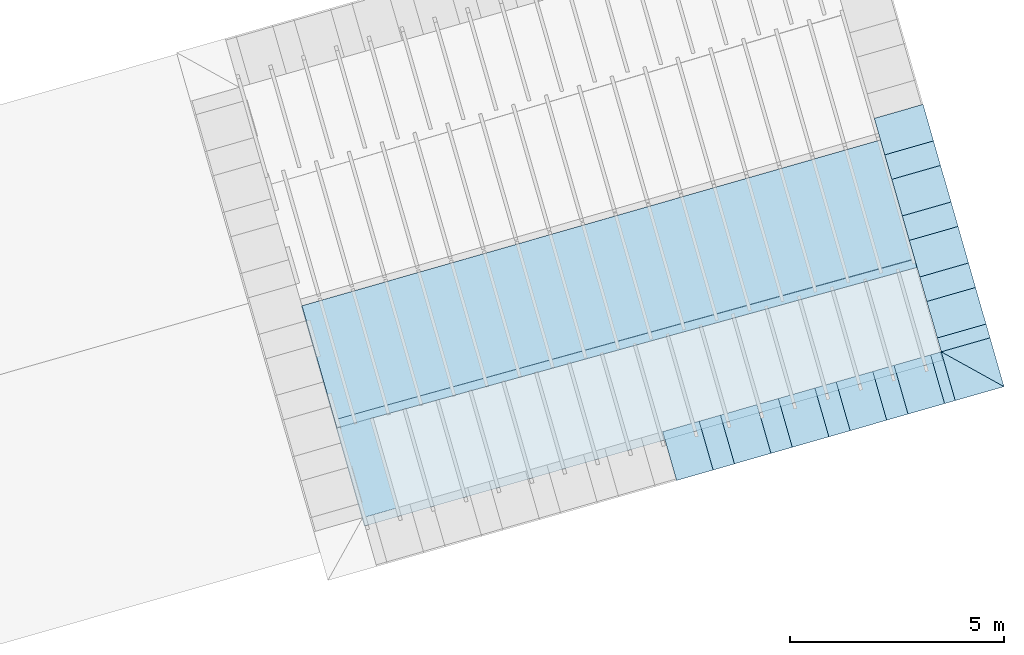
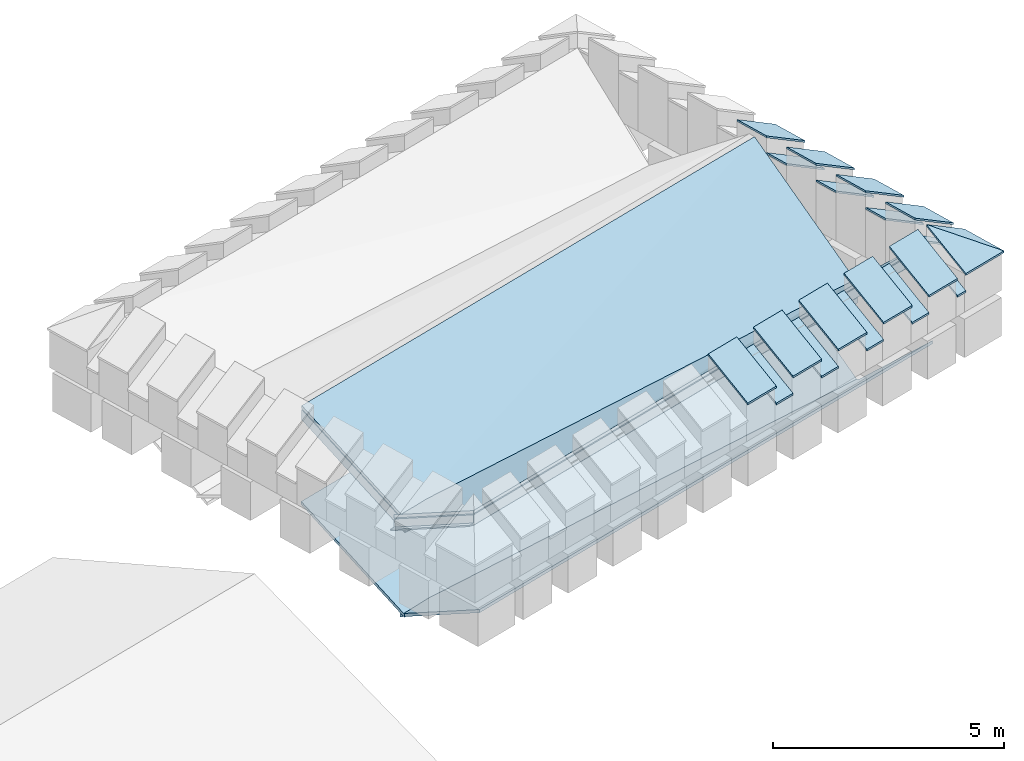
# One storey, part 3 of 10: 26 roofs.
"""IFC4 building model written with IfcOpenShell, lengths in metres."""

from ifc_helpers import new_model, entity, si_unit, converted_unit, derived_unit, direction, frame, origin_with_axes, place, context, subcontext, project, spatial, polygons, material, type_object, element, save


model = new_model("IFC4")

# Units and contexts
model_context = context("Model", 3, precision=1e-05, world=origin_with_axes(), true_north=direction((0.0, 1.0)))
body_context = subcontext(model_context, "Body", "Model", "MODEL_VIEW")
ifc_project = project(units=[si_unit("LENGTHUNIT", "METRE"), si_unit("AREAUNIT", "SQUARE_METRE"), si_unit("VOLUMEUNIT", "CUBIC_METRE"), converted_unit("PLANEANGLEUNIT", "DEGREE", entity("IfcPlaneAngleMeasure", 0.0174532925199433), si_unit("PLANEANGLEUNIT", "RADIAN"), dimensions=[0, 0, 0, 0, 0, 0, 0]), converted_unit("TIMEUNIT", "Year", entity("IfcTimeMeasure", 31557600.0), si_unit("TIMEUNIT", "SECOND"), dimensions=[0, 0, 1, 0, 0, 0, 0]), si_unit("MASSUNIT", "GRAM", prefix="KILO"), si_unit("THERMODYNAMICTEMPERATUREUNIT", "DEGREE_CELSIUS"), si_unit("LUMINOUSINTENSITYUNIT", "LUMEN"), si_unit("ENERGYUNIT", "JOULE", prefix="MEGA"), derived_unit("THERMALCONDUCTANCEUNIT", [(si_unit("POWERUNIT", "WATT"), 1), (si_unit("LENGTHUNIT", "METRE"), -1), (si_unit("THERMODYNAMICTEMPERATUREUNIT", "KELVIN"), -1)]), derived_unit("SPECIFICHEATCAPACITYUNIT", [(si_unit("ENERGYUNIT", "JOULE"), 1), (si_unit("MASSUNIT", "GRAM", prefix="KILO"), -1), (si_unit("THERMODYNAMICTEMPERATUREUNIT", "KELVIN"), -1)]), derived_unit("MASSDENSITYUNIT", [(si_unit("MASSUNIT", "GRAM", prefix="KILO"), 1), (si_unit("VOLUMEUNIT", "CUBIC_METRE"), -1)])], contexts=[model_context])

# Site, building, storey
site_placement = place(None, frame((0.0, 0.0, 0.0), z_axis=(0.0, 0.0, 1.0), x_axis=(0.9612616959383189, 0.2756373558169991, 0.0)))
site = spatial("IfcSite", under=ifc_project, at=site_placement, CompositionType="ELEMENT")
building_placement = place(site_placement, origin_with_axes())
building = spatial("IfcBuilding", under=site, at=building_placement, CompositionType="ELEMENT")
storey_placement = place(building_placement, frame((0.0, 0.0, 11.0), z_axis=(0.0, 0.0, 1.0), x_axis=(1.0, 0.0, 0.0)))
storey = spatial("IfcBuildingStorey", under=building, at=storey_placement, Name="Dach", CompositionType="ELEMENT", Elevation=11.0)

# Roofs
ifc_material_1 = material(Name="schwarz")
roof_type_1 = type_object("IfcRoofType", Name="schwarz 43", PredefinedType="NOTDEFINED")
roof_1_placement = place(storey_placement, frame((31.60143138517464, 8.011806750439922, 1.213699999999999), z_axis=(0.0, 0.0, 1.0), x_axis=(0.0, 1.0, 0.0)))
element("IfcRoof", 1, at=roof_1_placement, inside=storey, type_object=roof_type_1, material=ifc_material_1, Name="Dach-060", PredefinedType="NOTDEFINED", context=body_context, shape_type="Tessellation", body=[
    polygons([(0.8900025616952458, -0.03772698703640387, 0.02714466037988217), (0.8900025616952494, 1.149999999999988, 0.7466800857374203), (0.0, 1.149999999999991, 0.7466800857374274), (0.0, -0.03772698703641097, 0.02714466037987862), (0.8900025620847654, -0.03772698691103571, -0.02285533967409847), (0.8900025620847671, 1.150000000333105, 0.6966800858092981), (3.51640494500316e-10, 1.150000000333105, 0.6966800858092981), (3.516387181434766e-10, -0.03772698691103571, -0.02285533967409847)], [[[1, 2, 3, 4]], [[2, 1, 5, 6]], [[3, 2, 6, 7]], [[4, 3, 7, 8]], [[1, 4, 8, 5]], [[6, 5, 8, 7]]], closed=True),
])
roof_2_placement = place(storey_placement, frame((31.6014313850233, 9.498212015342238, 1.213699999999999), z_axis=(0.0, 0.0, 1.0), x_axis=(0.0, 1.0, 0.0)))
element("IfcRoof", 2, at=roof_2_placement, inside=storey, type_object=roof_type_1, material=ifc_material_1, Name="Dach-060", PredefinedType="NOTDEFINED", context=body_context, shape_type="Tessellation", body=[
    polygons([(0.8900025616952458, -0.03772698703641097, 0.02714466037987862), (0.8900025616952494, 1.149999999999984, 0.7466800857374238), (0.0, 1.149999999999999, 0.7466800857374309), (0.0, -0.03772698703641097, 0.02714466037987862), (0.8900025620847654, -0.03772698691103216, -0.02285533967409137), (0.8900025620847671, 1.150000000333108, 0.6966800858093052), (3.51640494500316e-10, 1.150000000333108, 0.6966800858093052), (3.516387181434766e-10, -0.03772698691103216, -0.02285533967409137)], [[[1, 2, 3, 4]], [[2, 1, 5, 6]], [[3, 2, 6, 7]], [[4, 3, 7, 8]], [[1, 4, 8, 5]], [[6, 5, 8, 7]]], closed=True),
])
roof_3_placement = place(storey_placement, frame((31.60143138487195, 10.98461728024455, 1.213699999999999), z_axis=(0.0, 0.0, 1.0), x_axis=(0.0, 1.0, 0.0)))
element("IfcRoof", 3, at=roof_3_placement, inside=storey, type_object=roof_type_1, material=ifc_material_1, Name="Dach-060", PredefinedType="NOTDEFINED", context=body_context, shape_type="Tessellation", body=[
    polygons([(0.8900025616952458, -0.03772698703640387, 0.02714466037988217), (0.8900025616952494, 1.149999999999988, 0.7466800857374203), (0.0, 1.150000000000002, 0.7466800857374274), (0.0, -0.03772698703641097, 0.02714466037987862), (0.8900025620847654, -0.0377269869110286, -0.02285533967409492), (0.8900025620847671, 1.150000000333112, 0.6966800858093016), (3.51640494500316e-10, 1.150000000333112, 0.6966800858093016), (3.516387181434766e-10, -0.0377269869110286, -0.02285533967409492)], [[[1, 2, 3, 4]], [[2, 1, 5, 6]], [[3, 2, 6, 7]], [[4, 3, 7, 8]], [[1, 4, 8, 5]], [[6, 5, 8, 7]]], closed=True),
])
roof_4_placement = place(storey_placement, frame((31.60143138472061, 12.47102254514687, 1.213699999999999), z_axis=(0.0, 0.0, 1.0), x_axis=(0.0, 1.0, 0.0)))
element("IfcRoof", 4, at=roof_4_placement, inside=storey, type_object=roof_type_1, material=ifc_material_1, Name="Dach-060", PredefinedType="NOTDEFINED", context=body_context, shape_type="Tessellation", body=[
    polygons([(0.8900025616952458, -0.03772698703641097, 0.02714466037987862), (0.8900025616952494, 1.149999999999988, 0.7466800857374238), (0.0, 1.149999999999999, 0.7466800857374309), (0.0, -0.03772698703641097, 0.02714466037987862), (0.8900025620847654, -0.0377269869110286, -0.02285533967409137), (0.8900025620847671, 1.150000000333112, 0.6966800858093052), (3.51640494500316e-10, 1.150000000333112, 0.6966800858093052), (3.516387181434766e-10, -0.0377269869110286, -0.02285533967409137)], [[[1, 2, 3, 4]], [[2, 1, 5, 6]], [[3, 2, 6, 7]], [[4, 3, 7, 8]], [[1, 4, 8, 5]], [[6, 5, 8, 7]]], closed=True),
])
roof_5_placement = place(storey_placement, frame((31.60143138517461, 9.498209312135137, 0.7745999999999995), z_axis=(0.0, 0.0, 1.0), x_axis=(0.0, -1.0, 0.0)))
element("IfcRoof", 5, at=roof_5_placement, inside=storey, type_object=roof_type_1, material=ifc_material_1, Name="Dach-059", PredefinedType="NOTDEFINED", context=body_context, shape_type="Tessellation", body=[
    polygons([(0.0, -1.149999999999999, 0.7466800857374309), (0.5964000000000027, -1.149999999999991, 0.7466800857374274), (0.5963999999999992, 0.03772698703645361, 0.02714466037985375), (0.0, 0.03772698703645361, 0.02714466037985375), (-3.895159750300081e-10, -1.150000000333108, 0.6966800858093052), (0.5963999997654561, -1.150000000333108, 0.6966800858093052), (0.5963999997654561, 0.03772698691103216, -0.02285533967409137), (-3.895159750300081e-10, 0.03772698691103216, -0.02285533967409137)], [[[1, 2, 3, 4]], [[2, 1, 5, 6]], [[3, 2, 6, 7]], [[4, 3, 7, 8]], [[1, 4, 8, 5]], [[6, 5, 8, 7]]], closed=True),
])
roof_6_placement = place(storey_placement, frame((31.60143138499301, 10.98461511767887, 0.7745999999999995), z_axis=(0.0, 0.0, 1.0), x_axis=(0.0, -1.0, 0.0)))
element("IfcRoof", 6, at=roof_6_placement, inside=storey, type_object=roof_type_1, material=ifc_material_1, Name="Dach-059", PredefinedType="NOTDEFINED", context=body_context, shape_type="Tessellation", body=[
    polygons([(0.0, -1.150000000000009, 0.746680085737438), (0.5964000000000027, -1.149999999999999, 0.7466800857374309), (0.5963999999999992, 0.03772698703645005, 0.0271446603798573), (0.0, 0.03772698703645005, 0.0271446603798573), (-3.895159750300081e-10, -1.150000000333122, 0.6966800858093123), (0.5963999997654561, -1.150000000333122, 0.6966800858093123), (0.5963999997654561, 0.0377269869110215, -0.02285533967408782), (-3.895159750300081e-10, 0.0377269869110215, -0.02285533967408782)], [[[1, 2, 3, 4]], [[2, 1, 5, 6]], [[3, 2, 6, 7]], [[4, 3, 7, 8]], [[1, 4, 8, 5]], [[6, 5, 8, 7]]], closed=True),
])
roof_7_placement = place(storey_placement, frame((31.6014313848114, 12.47102092322261, 0.7745999999999995), z_axis=(0.0, 0.0, 1.0), x_axis=(0.0, -1.0, 0.0)))
element("IfcRoof", 7, at=roof_7_placement, inside=storey, type_object=roof_type_1, material=ifc_material_1, Name="Dach-059", PredefinedType="NOTDEFINED", context=body_context, shape_type="Tessellation", body=[
    polygons([(0.0, -1.149999999999999, 0.7466800857374274), (0.5964000000000027, -1.149999999999995, 0.7466800857374238), (0.5963999999999992, 0.03772698703645361, 0.02714466037985019), (0.0, 0.03772698703645361, 0.02714466037985019), (-3.895159750300081e-10, -1.150000000333112, 0.6966800858093016), (0.5963999997654561, -1.150000000333112, 0.6966800858093016), (0.5963999997654561, 0.0377269869110286, -0.02285533967409492), (-3.895159750300081e-10, 0.0377269869110286, -0.02285533967409492)], [[[1, 2, 3, 4]], [[2, 1, 5, 6]], [[3, 2, 6, 7]], [[4, 3, 7, 8]], [[1, 4, 8, 5]], [[6, 5, 8, 7]]], closed=True),
])
roof_8_placement = place(storey_placement, frame((31.60143138169894, 8.011806975140747, 0.7745999999999995), z_axis=(0.0, 0.0, 1.0), x_axis=(0.0, -1.0, 0.0)))
element("IfcRoof", 8, at=roof_8_placement, inside=storey, type_object=roof_type_1, material=ifc_material_1, Name="Dach-058", PredefinedType="NOTDEFINED", context=body_context, shape_type="Tessellation", body=[
    polygons([(-7.37155403385259e-09, 0.03772698688034382, 0.0271446603290677), (2.247008605849032e-07, -1.149999996524294, 0.7466800945752929), (0.3364054846060407, -1.149999993345972, 0.7466800926498394), (0.3364054841255495, 0.03772698688034382, 0.0271446603290677), (-1.210476341384492e-08, 0.03772698706561783, -0.02285534011997115), (2.207258802400247e-07, -1.149999996857446, 0.6966800944403211), (0.3364054846092674, -1.14999999367123, 0.696680092510082), (0.3364054836779449, 0.03772698706561783, -0.02285534011997115)], [[[1, 2, 3, 4]], [[2, 1, 5, 6]], [[3, 2, 6, 7]], [[4, 3, 7, 8]], [[1, 4, 8, 5]], [[6, 5, 8, 7]]], closed=True),
])
roof_9_placement = place(storey_placement, frame((23.66662464075685, 6.525401474882883, 1.213699999999999), z_axis=(0.0, 0.0, 1.0), x_axis=(1.0, 0.0, 0.0)))
element("IfcRoof", 9, at=roof_9_placement, inside=storey, type_object=roof_type_1, material=ifc_material_1, Name="Dach-057", PredefinedType="NOTDEFINED", context=body_context, shape_type="Tessellation", body=[
    polygons([(0.8900025616952547, -0.03772698703644206, 0.0271446603798573), (0.8900025616952547, 1.15, 0.7466800857374345), (0.0, 1.15, 0.7466800857374345), (0.0, -0.03772698703644206, 0.0271446603798573), (0.8900025620847707, -0.03772698691103216, -0.0228553396740967), (0.8900025620847707, 1.150000000333107, 0.6966800858093052), (3.516440472139948e-10, 1.150000000333107, 0.6966800858093052), (3.516440472139948e-10, -0.03772698691103216, -0.0228553396740967)], [[[1, 2, 3, 4]], [[2, 1, 5, 6]], [[3, 2, 6, 7]], [[4, 3, 7, 8]], [[1, 4, 8, 5]], [[6, 5, 8, 7]]], closed=True),
])
roof_10_placement = place(storey_placement, frame((25.07558547708947, 6.525401478013255, 1.213699999999999), z_axis=(0.0, 0.0, 1.0), x_axis=(1.0, 0.0, 0.0)))
element("IfcRoof", 10, at=roof_10_placement, inside=storey, type_object=roof_type_1, material=ifc_material_1, Name="Dach-057", PredefinedType="NOTDEFINED", context=body_context, shape_type="Tessellation", body=[
    polygons([(0.8900025616952547, -0.03772698703644295, 0.0271446603798573), (0.8900025616952547, 1.15, 0.7466800857374345), (0.0, 1.149999999999999, 0.7466800857374345), (0.0, -0.03772698703644295, 0.0271446603798573), (0.8900025620847707, -0.03772698691103127, -0.0228553396740967), (0.8900025620847707, 1.150000000333108, 0.6966800858093052), (3.516440472139948e-10, 1.150000000333108, 0.6966800858093052), (3.516440472139948e-10, -0.03772698691103127, -0.0228553396740967)], [[[1, 2, 3, 4]], [[2, 1, 5, 6]], [[3, 2, 6, 7]], [[4, 3, 7, 8]], [[1, 4, 8, 5]], [[6, 5, 8, 7]]], closed=True),
])
roof_11_placement = place(storey_placement, frame((26.48454631342209, 6.525401481143627, 1.213699999999999), z_axis=(0.0, 0.0, 1.0), x_axis=(1.0, 0.0, 0.0)))
element("IfcRoof", 11, at=roof_11_placement, inside=storey, type_object=roof_type_1, material=ifc_material_1, Name="Dach-057", PredefinedType="NOTDEFINED", context=body_context, shape_type="Tessellation", body=[
    polygons([(0.8900025616952547, -0.03772698703644384, 0.02714466037985552), (0.8900025616952547, 1.149999999999999, 0.7466800857374327), (0.0, 1.149999999999999, 0.7466800857374327), (0.0, -0.03772698703644561, 0.02714466037985552), (0.8900025620847707, -0.03772698691103216, -0.02285533967409847), (0.8900025620847707, 1.150000000333106, 0.6966800858093034), (3.516440472139948e-10, 1.150000000333106, 0.6966800858093034), (3.516440472139948e-10, -0.03772698691103216, -0.02285533967409847)], [[[1, 2, 3, 4]], [[2, 1, 5, 6]], [[3, 2, 6, 7]], [[4, 3, 7, 8]], [[1, 4, 8, 5]], [[6, 5, 8, 7]]], closed=True),
])
roof_12_placement = place(storey_placement, frame((27.89346542439209, 6.525401487404372, 1.213659364809255), z_axis=(0.0, 0.0, 1.0), x_axis=(1.0, 0.0, 0.0)))
element("IfcRoof", 12, at=roof_12_placement, inside=storey, type_object=roof_type_1, material=ifc_material_1, Name="Dach-057", PredefinedType="NOTDEFINED", context=body_context, shape_type="Tessellation", body=[
    polygons([(0.8900025616952547, -0.03772698703644295, 0.02714466037985908), (0.8900025616952547, 1.149999999999999, 0.7466800857374345), (0.0, 1.149999999999999, 0.7466800857374345), (0.0, -0.03772698703644295, 0.02714466037985908), (0.8900025620847707, -0.03772698691103216, -0.0228553396740967), (0.8900025620847707, 1.150000000333107, 0.6966800858093052), (3.516440472139948e-10, 1.150000000333107, 0.6966800858093052), (3.516440472139948e-10, -0.03772698691103216, -0.0228553396740967)], [[[1, 2, 3, 4]], [[2, 1, 5, 6]], [[3, 2, 6, 7]], [[4, 3, 7, 8]], [[1, 4, 8, 5]], [[6, 5, 8, 7]]], closed=True),
])
roof_13_placement = place(storey_placement, frame((29.30246798608734, 6.525401487404372, 1.213699999999999), z_axis=(0.0, 0.0, 1.0), x_axis=(1.0, 0.0, 0.0)))
element("IfcRoof", 13, at=roof_13_placement, inside=storey, type_object=roof_type_1, material=ifc_material_1, Name="Dach-057", PredefinedType="NOTDEFINED", context=body_context, shape_type="Tessellation", body=[
    polygons([(0.8900025616952547, -0.03772698703644295, 0.0271446603798573), (0.8900025616952547, 1.149999999999999, 0.7466800857374345), (0.0, 1.149999999999999, 0.7466800857374345), (0.0, -0.03772698703644295, 0.0271446603798573), (0.8900025620847707, -0.03772698691103304, -0.0228553396740967), (0.8900025620847707, 1.150000000333106, 0.6966800858093052), (3.516440472139948e-10, 1.150000000333106, 0.6966800858093052), (3.516440472139948e-10, -0.03772698691103304, -0.0228553396740967)], [[[1, 2, 3, 4]], [[2, 1, 5, 6]], [[3, 2, 6, 7]], [[4, 3, 7, 8]], [[1, 4, 8, 5]], [[6, 5, 8, 7]]], closed=True),
])
roof_14_placement = place(storey_placement, frame((31.60143138835297, 6.525401490534742, 1.213699411030737), z_axis=(0.0, 0.0, 1.0), x_axis=(0.0, 1.0, 0.0)))
element("IfcRoof", 14, at=roof_14_placement, inside=storey, type_object=roof_type_1, material=ifc_material_1, Name="Dach-050", PredefinedType="NOTDEFINED", context=body_context, shape_type="Tessellation", body=[
    polygons([(1.149999999777758, -0.03772756924569265, 0.02714484985550847), (1.149999996544735, 1.149999999675053, 0.7466392677225802), (-0.03772756914296949, -0.03772756924566778, 0.02714484985552268), (1.15000000023677, -0.03772756894329277, -0.02285437849470462), (1.14999999651148, 1.150000000079416, 0.6966400394341346), (-0.03772756943687394, -0.03772756894329277, -0.02285437849470462)], [[[1, 2, 3]], [[2, 1, 4, 5]], [[3, 2, 5, 6]], [[1, 3, 6, 4]], [[5, 4, 6]]], closed=True),
])
roof_15_placement = place(storey_placement, frame((30.45143138835297, 6.525401490534707, 1.213699411030737), z_axis=(0.0, 0.0, 1.0), x_axis=(1.0, 0.0, 0.0)))
element("IfcRoof", 15, at=roof_15_placement, inside=storey, type_object=roof_type_1, material=ifc_material_1, Name="Dach-049", PredefinedType="NOTDEFINED", context=body_context, shape_type="Tessellation", body=[
    polygons([(1.187727569245677, -0.03772756914296682, 0.02714484989206234), (0.0, 1.149999996869653, 0.7466392679559526), (0.0, -0.0377275691429686, 0.02714484989206234), (1.187727569633864, -0.03772756928762089, -0.02285437876549956), (0.0, 1.149999997201504, 0.6966400395870433), (0.0, -0.03772756928762089, -0.02285437876549956)], [[[1, 2, 3]], [[2, 1, 4, 5]], [[3, 2, 5, 6]], [[1, 3, 6, 4]], [[5, 4, 6]]], closed=True),
])
roof_16_placement = place(storey_placement, frame((27.37454887510356, 6.543388480039594, 0.774556042697311), z_axis=(0.0, 0.0, 1.0), x_axis=(1.0, 0.0, 0.0)))
element("IfcRoof", 16, at=roof_16_placement, inside=storey, type_object=roof_type_1, material=ifc_material_1, Name="Dach-048", PredefinedType="NOTDEFINED", context=body_context, shape_type="Tessellation", body=[
    polygons([(0.5189582746531372, -0.05571398314985654, 0.01624798038468356), (0.51895827465313, 1.132013003886586, 0.7357834057422608), (0.0, 1.132013003886584, 0.735783405742259), (0.0, -0.0557139831498592, 0.01624798038468178), (0.5189582750426531, -0.05571398302444663, -0.03375201966927044), (0.5189582750426531, 1.132013004219693, 0.6857834058141314), (-1.637339153148787e-10, 1.132013004219693, 0.6857834058141314), (-1.637339153148787e-10, -0.05571398302444663, -0.03375201966927044)], [[[1, 2, 3, 4]], [[2, 1, 5, 6]], [[3, 2, 6, 7]], [[4, 3, 7, 8]], [[1, 4, 8, 5]], [[6, 5, 8, 7]]], closed=True),
])
roof_17_placement = place(storey_placement, frame((28.78350971143421, 6.543388483517785, 0.7745999999999995), z_axis=(0.0, 0.0, 1.0), x_axis=(1.0, 0.0, 0.0)))
element("IfcRoof", 17, at=roof_17_placement, inside=storey, type_object=roof_type_1, material=ifc_material_1, Name="Dach-048", PredefinedType="NOTDEFINED", context=body_context, shape_type="Tessellation", body=[
    polygons([(0.5189582746531372, -0.05571398314985654, 0.01624798038468178), (0.51895827465313, 1.132013003886586, 0.735783405742259), (0.0, 1.132013003886584, 0.7357834057422572), (0.0, -0.05571398314985831, 0.01624798038468001), (0.5189582750426531, -0.05571398302444575, -0.03375201966927222), (0.5189582750426531, 1.132013004219693, 0.6857834058141297), (-1.637339153148787e-10, 1.132013004219693, 0.6857834058141297), (-1.637339153148787e-10, -0.05571398302444575, -0.03375201966927222)], [[[1, 2, 3, 4]], [[2, 1, 5, 6]], [[3, 2, 6, 7]], [[4, 3, 7, 8]], [[1, 4, 8, 5]], [[6, 5, 8, 7]]], closed=True),
])
roof_18_placement = place(storey_placement, frame((24.55662720244226, 6.543388473083212, 0.7745999999999995), z_axis=(0.0, 0.0, 1.0), x_axis=(1.0, 0.0, 0.0)))
element("IfcRoof", 18, at=roof_18_placement, inside=storey, type_object=roof_type_1, material=ifc_material_1, Name="Dach-048", PredefinedType="NOTDEFINED", context=body_context, shape_type="Tessellation", body=[
    polygons([(0.5189582746531372, -0.05571398314985565, 0.01624798038468178), (0.51895827465313, 1.132013003886586, 0.735783405742259), (0.0, 1.132013003886585, 0.7357834057422572), (0.0, -0.05571398314985831, 0.01624798038468001), (0.5189582750426531, -0.05571398302444575, -0.03375201966927222), (0.5189582750426531, 1.132013004219694, 0.6857834058141297), (-1.637339153148787e-10, 1.132013004219694, 0.6857834058141297), (-1.637339153148787e-10, -0.05571398302444575, -0.03375201966927222)], [[[1, 2, 3, 4]], [[2, 1, 5, 6]], [[3, 2, 6, 7]], [[4, 3, 7, 8]], [[1, 4, 8, 5]], [[6, 5, 8, 7]]], closed=True),
])
roof_19_placement = place(storey_placement, frame((25.96558803877291, 6.543388476561403, 0.7745999999999995), z_axis=(0.0, 0.0, 1.0), x_axis=(1.0, 0.0, 0.0)))
element("IfcRoof", 19, at=roof_19_placement, inside=storey, type_object=roof_type_1, material=ifc_material_1, Name="Dach-048", PredefinedType="NOTDEFINED", context=body_context, shape_type="Tessellation", body=[
    polygons([(0.5189582746531372, -0.05571398314985743, 0.01624798038468178), (0.51895827465313, 1.132013003886587, 0.7357834057422608), (0.0, 1.132013003886583, 0.7357834057422572), (0.0, -0.05571398314985831, 0.01624798038468001), (0.5189582750426531, -0.05571398302444486, -0.03375201966927044), (0.5189582750426531, 1.132013004219694, 0.6857834058141314), (-1.637339153148787e-10, 1.132013004219694, 0.6857834058141314), (-1.637339153148787e-10, -0.05571398302444486, -0.03375201966927044)], [[[1, 2, 3, 4]], [[2, 1, 5, 6]], [[3, 2, 6, 7]], [[4, 3, 7, 8]], [[1, 4, 8, 5]], [[6, 5, 8, 7]]], closed=True),
])
roof_20_placement = place(storey_placement, frame((30.19246977131029, 6.543388486648118, 0.7745999999999995), z_axis=(0.0, 0.0, 1.0), x_axis=(1.0, 0.0, 0.0)))
element("IfcRoof", 20, at=roof_20_placement, inside=storey, type_object=roof_type_1, material=ifc_material_1, Name="Dach-048", PredefinedType="NOTDEFINED", context=body_context, shape_type="Tessellation", body=[
    polygons([(0.2589616170426865, -0.05571398314985654, 0.01624798038468178), (0.2589616170426936, 1.132013003886585, 0.735783405742259), (0.0, 1.132013003886587, 0.7357834057422608), (0.0, -0.05571398314985565, 0.01624798038468356), (0.2589616174322096, -0.05571398302444486, -0.03375201966927044), (0.2589616174322096, 1.132013004219694, 0.6857834058141314), (4.1690739749356e-10, 1.132013004219694, 0.6857834058141314), (4.1690739749356e-10, -0.05571398302444486, -0.03375201966927044)], [[[1, 2, 3, 4]], [[2, 1, 5, 6]], [[3, 2, 6, 7]], [[4, 3, 7, 8]], [[1, 4, 8, 5]], [[6, 5, 8, 7]]], closed=True),
])
ifc_material_2 = material(Name="Mineralwolle 2")
roof_type_2 = type_object("IfcRoofType", Name="Mineralwolle 2", PredefinedType="NOTDEFINED")
roof_21_placement = place(storey_placement, frame((-32.67581060663868, 0.1466823914080386, -11.3401966749038), z_axis=(0.0, 0.0, 1.0), x_axis=(1.0, 0.0, 0.0)))
element("IfcRoof", 21, at=roof_21_placement, inside=storey, type_object=roof_type_2, material=ifc_material_2, Name="Dach-005", PredefinedType="NOTDEFINED", context=body_context, shape_type="Tessellation", body=[
    polygons([(49.01725441794425, 7.526717329425702, 12.48631507876694), (48.91623288384299, 7.526717152783544, 12.48631474673754), (48.91623288382571, 9.910453172159267, 11.21814778614168), (49.01725441792901, 9.910453348801425, 11.21814811817108), (49.01725451101589, 7.526717329411352, 12.4579973204252), (49.83242060735748, 7.526718754771042, 12.4579999996466), (63.12090365273619, 7.526718754629461, 12.45805605322565), (63.12090365273619, 7.526718754637136, 12.4668871827851), (63.12090365273619, 7.52671875463898, 12.46900952098939), (63.12090365273619, 7.526718754654071, 12.48637381156233), (63.12090365273619, 7.526718754683602, 12.52035512100934), (63.12090365273619, 7.526718754841101, 12.70158877139339), (63.12090365273619, 7.526718754870632, 12.73557008008085), (49.8324196952554, 7.526718754911668, 12.73551402655145), (49.03241898093739, 7.526717356064312, 12.73551139717435), (49.03241898228453, 7.526717356049073, 12.70153008848049), (49.03241957794302, 7.526717355957235, 12.52029643806402), (48.91623277215702, 7.526717152800764, 12.52029605619062), (48.91623277213974, 9.910453173326877, 11.25212909498275), (49.03241957791901, 9.910453376483346, 11.25212947685614), (49.03241898226052, 9.910453382710594, 11.43336312400852), (49.03241898094629, 9.91045338387622, 11.46734443209037), (49.83241969526226, 9.910454782723578, 11.46734706146747), (49.83241980695028, 9.91045478155597, 11.43336575338594), (49.83242040261973, 9.910454775328724, 11.25213210623356), (49.83242051430775, 9.910454774161114, 11.21815079739249), (49.8324206073811, 9.910454773188107, 11.18983303956076), (49.01725451100065, 9.910453347828417, 11.18983036033935), (63.12093931417802, 9.701624016414732, 10.2615782948578), (63.12093931522156, 9.701687658855539, 10.65523738074027), (63.12094069983237, 9.786131729518738, 10.5826654639523), (63.12094069983237, 9.786131729514391, 10.58146161552495), (63.1209407710363, 9.790474286065868, 10.30503481464133), (63.1209407710363, 9.790474286034227, 10.29828079400867), (63.12094078538213, 9.791349203685257, 10.25067014409473), (63.12094078538213, 9.79134920367899, 10.24939116692629), (63.12094079620453, 9.792009235600363, 10.21456624115422), (63.12094079620453, 9.792009235594925, 10.21349250680425), (63.12094034315177, 9.764378641093067, 10.22819224336584), (63.12093986320171, 9.735107645063142, 10.24376468899331), (63.12094069289841, 9.785708844818, 10.61053733035394)], [[[1, 2, 3, 4]], [[2, 1, 5, 6, 7, 8, 9, 10, 11, 12, 13, 14, 15, 16, 17, 18]], [[2, 18, 19, 3]], [[4, 3, 19, 20, 21, 22, 23, 24, 25, 26, 27, 28]], [[5, 1, 4, 28]], [[5, 28, 27, 6]], [[7, 6, 29]], [[14, 13, 30]], [[22, 15, 14, 23]], [[16, 15, 22, 21]], [[17, 16, 21, 20]], [[18, 17, 20, 19]], [[24, 23, 31, 32]], [[24, 33, 34, 25]], [[26, 25, 35, 36]], [[27, 26, 37, 38]], [[6, 27, 38, 39, 40, 29]], [[41, 23, 14, 30]], [[23, 41, 31]], [[33, 24, 32]], [[25, 34, 35]], [[36, 37, 26]]], closed=False),
    polygons([(62.980048980997, 9.755524186557253, 10.49244476836244), (62.89257694422515, 7.500677341807842, 12.46262865117778), (63.00638124672686, 9.759788486013356, 10.20362950782021), (63.12090338075168, 7.510131076251311, 12.48358552839767), (63.12094029361833, 9.76135771628415, 10.50537643753256), (63.12090365273619, 7.52671875463898, 12.46900952098939), (63.12090365273619, 7.526718754637136, 12.4668871827851), (63.12093986320171, 9.735107645063142, 10.24376468899331), (63.12094034566218, 9.764531744463378, 10.21414428222537), (63.12094034315177, 9.764378641093067, 10.22819224336584)], [[[1, 2, 3]], [[4, 2, 1, 5, 6]], [[2, 4, 7, 8, 9, 3]], [[3, 9, 10, 5, 1]]], closed=False),
])
roof_22_placement = place(storey_placement, frame((-32.67581060663868, 0.1466823914080386, -11.3401966749038), z_axis=(0.0, 0.0, 1.0), x_axis=(1.0, 0.0, 0.0)))
element("IfcRoof", 22, at=roof_22_placement, inside=storey, type_object=roof_type_2, material=ifc_material_2, Name="Dach-005", PredefinedType="NOTDEFINED", context=body_context, shape_type="Tessellation", body=[
    polygons([(49.03241895488413, 7.526717356106333, 12.82046467080795), (49.0324189487643, 7.526717356119908, 12.84878242868575), (49.03241894872675, 9.910453387766449, 11.58061546156172), (49.03241895484933, 9.910453386794217, 11.55229770419392), (49.03241914102741, 7.526717356077633, 12.7638291550528), (49.83241960218377, 7.526718754926017, 12.76383178442902), (63.12090365273619, 7.526718754895241, 12.76388783795336), (63.12090365273619, 7.52671875494446, 12.82052335369838), (63.12090365273619, 7.526718754969069, 12.84884111157088), (49.83241932296885, 7.526718754969067, 12.84878505806174), (49.83241932296885, 9.910454786615608, 11.5806180909377), (49.03241914099262, 9.910453384848202, 11.4956621894588), (49.83241941604221, 9.910454785642601, 11.55230033357015), (49.83241960218891, 9.910454783696586, 11.49566481883503), (63.12093931529781, 9.701692308706782, 10.68720237413882), (63.12093931551461, 9.701705531299408, 10.78448405943876), (63.1209406639095, 9.783940881024098, 10.74073409211993), (63.12094067203195, 9.784436249593634, 10.70409110526153), (63.12094067203195, 9.784436249590497, 10.70310824331149), (63.12094068535443, 9.785248754889109, 10.64473479342037), (63.12094068535443, 9.785248754882375, 10.64274957000672)], [[[1, 2, 3, 4]], [[1, 5, 6, 7, 8, 9, 10, 2]], [[2, 10, 11, 3]], [[12, 4, 3, 11, 13, 14]], [[5, 1, 4, 12]], [[5, 12, 14, 6]], [[7, 6, 15]], [[10, 9, 16]], [[11, 10, 16, 17]], [[13, 11, 18, 19]], [[14, 13, 20, 21]], [[15, 6, 14, 21]], [[11, 17, 18]], [[13, 19, 20]]], closed=False),
])
roof_23_placement = place(storey_placement, frame((79.48408732588638, 25.88249447795959, -11.32434781702759), z_axis=(0.0, 0.0, 1.0), x_axis=(-0.9999999998424299, 1.775219516859179e-05, 0.0)))
element("IfcRoof", 23, at=roof_23_placement, inside=storey, type_object=roof_type_2, material=ifc_material_2, Name="Dach-004", PredefinedType="NOTDEFINED", context=body_context, shape_type="Tessellation", body=[
    polygons([(49.03242135674516, 13.04734108985332, 12.9502049427386), (49.03242088729236, 13.04734108982853, 12.98339928620701), (49.03242003992625, 16.14734106686427, 10.56989730110458), (49.03242001087519, 16.14734106880073, 10.53748664567232), (63.12099311436386, 13.04734108961325, 12.95044889908386), (63.1209926449473, 13.04734108964386, 12.98364324252603), (63.120992629255, 16.1473410897189, 11.51549334077637), (63.12099309865152, 16.14734108971081, 11.48229899732354), (49.03242386049354, 13.04734108998552, 12.77316844028338), (49.03241965870473, 16.14734108408878, 10.2903223522107), (63.12099561791889, 13.04734108944999, 12.77341239676856), (63.12099560209978, 16.14734108966761, 11.30526249495138), (49.03241946195324, 16.14734108754209, 10.2428083424142), (49.03242432994635, 13.04734109001031, 12.73997409607302), (63.12099608733547, 13.04734108941938, 12.74021805258444), (63.12099607149634, 16.14734108965951, 11.2720681507566), (49.03241932300209, 16.14734108974591, 10.2134361772507), (49.03242472115704, 13.04734109003097, 12.71231214211098), (63.12099647851595, 13.04734108939387, 12.71255609864426), (63.12099646266013, 16.14734108965276, 11.24440619680753)], [[[1, 2, 3, 4]], [[2, 1, 5, 6]], [[3, 2, 7]], [[4, 3, 7, 8]], [[9, 1, 4, 10]], [[1, 9, 11, 5]], [[5, 8, 7, 6]], [[2, 6, 7]], [[10, 4, 8, 12]], [[9, 10, 13, 14]], [[9, 14, 15, 11]], [[11, 12, 8, 5]], [[13, 10, 12, 16]], [[13, 17, 18, 14]], [[14, 18, 19, 15]], [[12, 11, 15, 16]], [[17, 13, 16, 20]], [[18, 17, 20]], [[20, 19, 18]], [[15, 19, 20, 16]]], closed=True),
])
roof_24_placement = place(storey_placement, frame((79.48408726716973, 25.88249447808946, -11.3285), z_axis=(0.0, 0.0, 1.0), x_axis=(-0.9999999998424299, 1.775219516859179e-05, 0.0)))
element("IfcRoof", 24, at=roof_24_placement, inside=storey, type_object=roof_type_2, material=ifc_material_2, Name="Dach-004", PredefinedType="NOTDEFINED", context=body_context, shape_type="Tessellation", body=[
    polygons([(49.0324199444231, 16.14734105872517, 10.72350971299233), (49.03241932244963, 13.0473410897459, 13.09404710024153), (63.12099106459983, 16.14734108974591, 11.62614115475898), (49.03241971366032, 13.04734108976656, 13.0663851467329), (49.03241998149972, 16.14734106160567, 10.66971724682379), (63.12099108022539, 13.0473410897459, 13.09429105647309), (63.12099145576363, 16.14734108973915, 11.59847920126333), (63.12099147140587, 13.04734108972039, 13.06662910298633), (49.03241999928467, 16.1473410650059, 10.60806260237096), (49.03242049608168, 13.04734108980787, 13.01106123971564), (63.1209922380912, 16.14734108972565, 11.54315529427202), (63.12099225376682, 13.04734108966937, 13.0113051960128)], [[[1, 2, 3]], [[4, 2, 1, 5]], [[2, 6, 3]], [[5, 1, 3, 7]], [[2, 4, 8, 6]], [[5, 9, 10, 4]], [[6, 8, 7, 3]], [[9, 5, 7, 11]], [[4, 10, 12, 8]], [[10, 9, 11]], [[7, 8, 12, 11]], [[12, 10, 11]]], closed=True),
])
roof_25_placement = place(storey_placement, frame((-32.68836013058092, -0.05127056547971343, -13.84878242868575), z_axis=(0.0, 0.0, 1.0), x_axis=(1.0, 0.0, 0.0)))
element("IfcRoof", 25, at=roof_25_placement, inside=storey, type_object=roof_type_2, material=ifc_material_2, Name="Dach-005", PredefinedType="NOTDEFINED", context=body_context, shape_type="Tessellation", body=[
    polygons([(49.03241895488413, 7.526717356106333, 12.82046467080795), (49.0324189487643, 7.526717356119908, 12.84878242868575), (49.03241894872675, 9.910453387766449, 11.58061546156172), (49.03241895484933, 9.910453386794217, 11.55229770419392), (49.03241914102741, 7.526717356077633, 12.7638291550528), (49.83241960218377, 7.526718754926017, 12.76383178442902), (63.12090365273619, 7.526718754895241, 12.76388783795336), (63.12090365273619, 7.52671875494446, 12.82052335369838), (63.12090365273619, 7.526718754969069, 12.84884111157088), (49.83241932296885, 7.526718754969067, 12.84878505806174), (49.83241932296885, 9.910454786615608, 11.5806180909377), (49.03241914099262, 9.910453384848202, 11.4956621894588), (49.83241941604221, 9.910454785642601, 11.55230033357015), (49.83241960218891, 9.910454783696586, 11.49566481883503), (63.12093931529781, 9.701692308706782, 10.68720237413882), (63.12093931551461, 9.701705531299408, 10.78448405943876), (63.1209406639095, 9.783940881024098, 10.74073409211993), (63.12094067203195, 9.784436249593634, 10.70409110526153), (63.12094067203195, 9.784436249590497, 10.70310824331149), (63.12094068535443, 9.785248754889109, 10.64473479342037), (63.12094068535443, 9.785248754882375, 10.64274957000672)], [[[1, 2, 3, 4]], [[1, 5, 6, 7, 8, 9, 10, 2]], [[2, 10, 11, 3]], [[12, 4, 3, 11, 13, 14]], [[5, 1, 4, 12]], [[5, 12, 14, 6]], [[7, 6, 15]], [[10, 9, 16]], [[11, 10, 16, 17]], [[13, 11, 18, 19]], [[14, 13, 20, 21]], [[15, 6, 14, 21]], [[11, 17, 18]], [[13, 19, 20]]], closed=False),
])
roof_26_placement = place(storey_placement, frame((79.46528683209357, 25.88254117918421, -13.84878242868575), z_axis=(0.0, 0.0, 1.0), x_axis=(-0.9999999998424299, 1.775219516859179e-05, 0.0)))
element("IfcRoof", 26, at=roof_26_placement, inside=storey, type_object=roof_type_2, material=ifc_material_2, Name="Dach-004", PredefinedType="NOTDEFINED", context=body_context, shape_type="Tessellation", body=[
    polygons([(49.0324199444231, 16.14734105872517, 10.72350971299233), (49.03241932244963, 13.0473410897459, 13.09404710024153), (63.12099106459983, 16.1473410897459, 11.62614115475898), (49.0324197136603, 13.04734108976656, 13.0663851467329), (49.03241998149971, 16.14734106160567, 10.66971724682379), (63.12099108022539, 13.0473410897459, 13.09429105647309), (63.12099145576362, 16.14734108973915, 11.59847920126333), (63.12099147140587, 13.04734108972039, 13.06662910298633), (49.03241999928466, 16.1473410650059, 10.60806260237096), (49.03242049608167, 13.04734108980787, 13.01106123971564), (63.1209922380912, 16.14734108972565, 11.54315529427202), (63.12099225376681, 13.04734108966937, 13.0113051960128)], [[[1, 2, 3]], [[4, 2, 1, 5]], [[2, 6, 3]], [[5, 1, 3, 7]], [[2, 4, 8, 6]], [[5, 9, 10, 4]], [[6, 8, 7, 3]], [[9, 5, 7, 11]], [[4, 10, 12, 8]], [[10, 9, 11]], [[7, 8, 12, 11]], [[12, 10, 11]]], closed=True),
])

save(model, "model.ifc")
